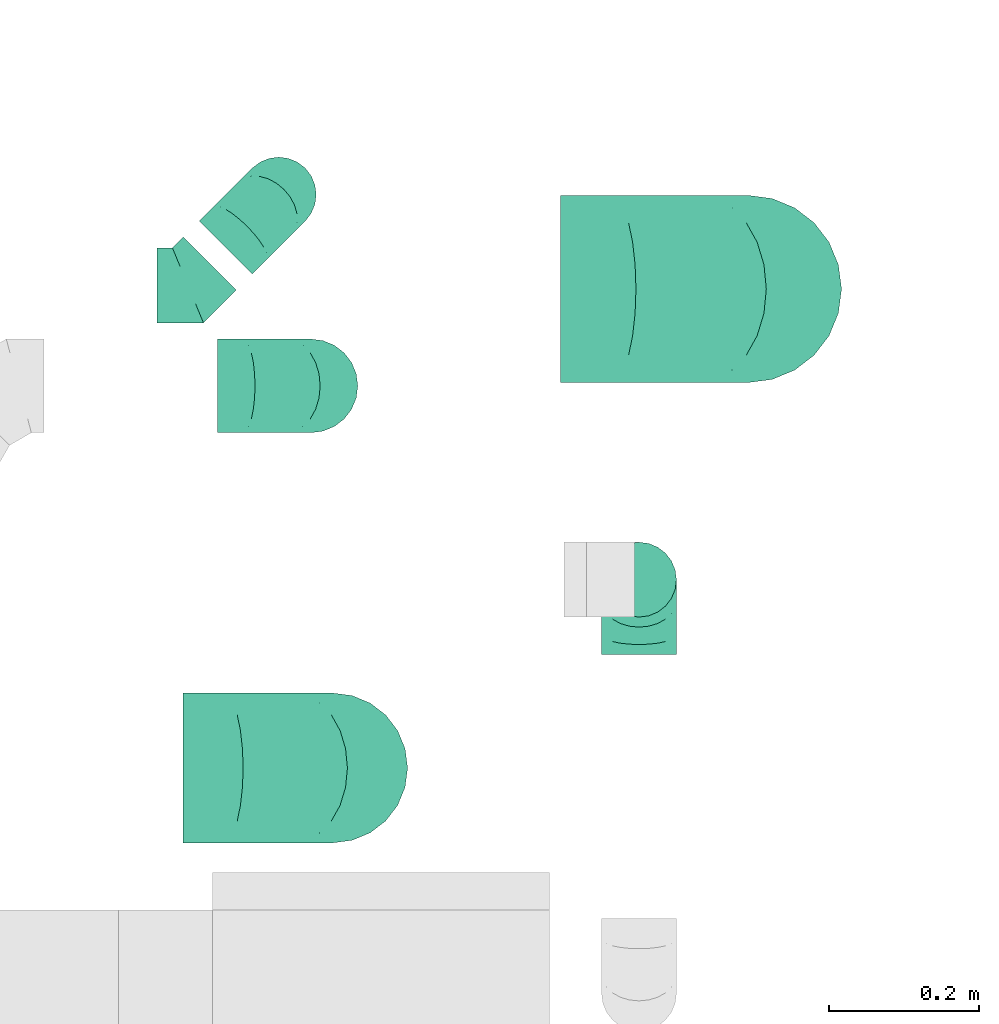
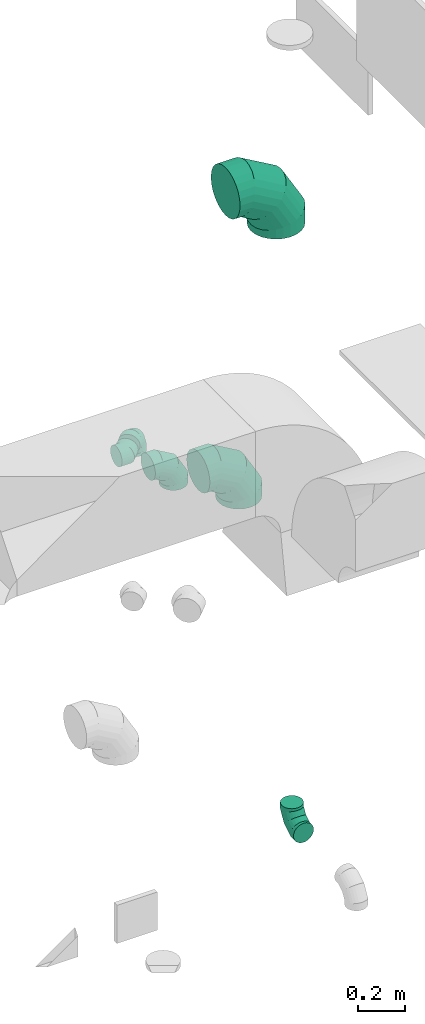
# One storey, part 39 of 59: 6 flow fittings.
"""IFC2X3 building model written with IfcOpenShell, lengths in millimetres."""

from ifc_helpers import new_model, entity, si_unit, converted_unit, derived_unit, direction, frame, origin, place, context, subcontext, project, spatial, faceted_brep, source, transform, mapped, material, type_object, type_shapes, element, save


model = new_model("IFC2X3")

# Units and contexts
model_context = context("Model", 3, precision=0.01, world=origin(), true_north=direction((6.12303176911189e-17, 1.0)))
body_context = subcontext(model_context, "Body", "Model", "MODEL_VIEW")
ifc_project = project(units=[si_unit("LENGTHUNIT", "METRE", prefix="MILLI"), si_unit("AREAUNIT", "SQUARE_METRE"), si_unit("VOLUMEUNIT", "CUBIC_METRE"), converted_unit("PLANEANGLEUNIT", "DEGREE", entity("IfcRatioMeasure", 0.0174532925199433), si_unit("PLANEANGLEUNIT", "RADIAN"), dimensions=[0, 0, 0, 0, 0, 0, 0]), si_unit("MASSUNIT", "GRAM", prefix="KILO"), derived_unit("MASSDENSITYUNIT", [(si_unit("MASSUNIT", "GRAM", prefix="KILO"), 1), (si_unit("LENGTHUNIT", "METRE"), -3)]), derived_unit("MOMENTOFINERTIAUNIT", [(si_unit("LENGTHUNIT", "METRE"), 4)]), si_unit("TIMEUNIT", "SECOND"), si_unit("FREQUENCYUNIT", "HERTZ"), si_unit("THERMODYNAMICTEMPERATUREUNIT", "DEGREE_CELSIUS"), derived_unit("THERMALTRANSMITTANCEUNIT", [(si_unit("MASSUNIT", "GRAM", prefix="KILO"), 1), (si_unit("THERMODYNAMICTEMPERATUREUNIT", "KELVIN"), -1), (si_unit("TIMEUNIT", "SECOND"), -3)]), derived_unit("VOLUMETRICFLOWRATEUNIT", [(si_unit("LENGTHUNIT", "METRE"), 3), (si_unit("TIMEUNIT", "SECOND"), -1)]), derived_unit("MASSFLOWRATEUNIT", [(si_unit("MASSUNIT", "GRAM", prefix="KILO"), 1), (si_unit("TIMEUNIT", "SECOND"), -1)]), derived_unit("ROTATIONALFREQUENCYUNIT", [(si_unit("TIMEUNIT", "SECOND"), -1)]), si_unit("ELECTRICCURRENTUNIT", "AMPERE"), si_unit("ELECTRICVOLTAGEUNIT", "VOLT"), si_unit("POWERUNIT", "WATT"), si_unit("FORCEUNIT", "NEWTON", prefix="KILO"), si_unit("ILLUMINANCEUNIT", "LUX"), si_unit("LUMINOUSFLUXUNIT", "LUMEN"), si_unit("LUMINOUSINTENSITYUNIT", "CANDELA"), derived_unit("USERDEFINED", [(si_unit("MASSUNIT", "GRAM", prefix="KILO"), -1), (si_unit("LENGTHUNIT", "METRE"), -2), (si_unit("TIMEUNIT", "SECOND"), 3), (si_unit("LUMINOUSFLUXUNIT", "LUMEN"), 1)]), derived_unit("LINEARVELOCITYUNIT", [(si_unit("LENGTHUNIT", "METRE"), 1), (si_unit("TIMEUNIT", "SECOND"), -1)]), si_unit("PRESSUREUNIT", "PASCAL"), derived_unit("USERDEFINED", [(si_unit("LENGTHUNIT", "METRE"), -2), (si_unit("MASSUNIT", "GRAM", prefix="KILO"), 1), (si_unit("TIMEUNIT", "SECOND"), -2)]), derived_unit("LINEARFORCEUNIT", [(si_unit("MASSUNIT", "GRAM", prefix="KILO"), 1), (si_unit("LENGTHUNIT", "METRE"), 1), (si_unit("TIMEUNIT", "SECOND"), -2), (si_unit("LENGTHUNIT", "METRE"), -1)]), derived_unit("PLANARFORCEUNIT", [(si_unit("MASSUNIT", "GRAM", prefix="KILO"), 1), (si_unit("LENGTHUNIT", "METRE"), 1), (si_unit("TIMEUNIT", "SECOND"), -2), (si_unit("LENGTHUNIT", "METRE"), -2)])], contexts=[model_context])

# Site, building, storey
site_placement = place(None, origin())
site = spatial("IfcSite", under=ifc_project, at=site_placement, CompositionType="ELEMENT")
building_placement = place(site_placement, origin())
building = spatial("IfcBuilding", under=site, at=building_placement, CompositionType="ELEMENT")
storey_placement = place(building_placement, frame((0.0, 0.0, 28200.0)))
storey = spatial("IfcBuildingStorey", under=building, at=storey_placement, CompositionType="ELEMENT", Elevation=28200.0)

# Flow fittings
ifc_material = material()
duct_fitting_type_1 = type_object("IfcDuctFittingType", PredefinedType="NOTDEFINED", material=ifc_material)
shared_shape_1 = source(origin(), body_context, "Body", "Brep", [
    faceted_brep([(-100.0, 0.0, -50.0), (-100.0, -12.94, -48.3), (-100.0, -25.0, -43.3), (-100.0, -35.36, -35.36), (-100.0, -43.3, -25.0), (-100.0, -48.3, -12.94), (-100.0, -50.0, 0.0), (-100.0, -48.3, 12.94), (-100.0, -43.3, 25.0), (-100.0, -35.36, 35.36), (-100.0, -25.0, 43.3), (-100.0, -12.94, 48.3), (-100.0, 0.0, 50.0), (-100.0, 12.94, 48.3), (-100.0, 25.0, 43.3), (-100.0, 35.36, 35.36), (-100.0, 43.3, 25.0), (-100.0, 48.3, 12.94), (-100.0, 50.0, 0.0), (-100.0, 48.3, -12.94), (-100.0, 43.3, -25.0), (-100.0, 35.36, -35.36), (-100.0, 25.0, -43.3), (-100.0, 12.94, -48.3), (-76.67, 12.94, 48.3), (-79.9, 25.0, 43.3), (-73.21, 0.0, 50.0), (-82.68, 35.36, 35.36), (-86.15, 48.3, 12.94), (-86.6, 50.0, 0.0), (-84.81, 43.3, 25.0), (-84.81, 43.3, -25.0), (-82.68, 35.36, -35.36), (-86.15, 48.3, -12.94), (-76.67, 12.94, -48.3), (-73.21, 0.0, -50.0), (-79.9, 25.0, -43.3), (-69.74, -12.94, -48.3), (-66.51, -25.0, -43.3), (-63.73, -35.36, -35.36), (-61.6, -43.3, -25.0), (-60.26, -48.3, -12.94), (-59.81, -50.0, 0.0), (-60.26, -48.3, 12.94), (-61.6, -43.3, 25.0), (-63.73, -35.36, 35.36), (-66.51, -25.0, 43.3), (-69.74, -12.94, 48.3), (-36.27, 36.27, 48.3), (-45.1, 45.1, 43.3), (-26.79, 26.79, 50.0), (-52.68, 52.68, 35.36), (-58.49, 58.49, 25.0), (-62.15, 62.15, 12.94), (-63.4, 63.4, 0.0), (-62.15, 62.15, -12.94), (-58.49, 58.49, -25.0), (-52.68, 52.68, -35.36), (-36.27, 36.27, -48.3), (-26.79, 26.79, -50.0), (-45.1, 45.1, -43.3), (-17.32, 17.32, -48.3), (-8.49, 8.49, -43.3), (-0.91, 0.91, -35.36), (4.9, -4.9, -25.0), (8.56, -8.56, -12.94), (9.81, -9.81, 0.0), (8.56, -8.56, 12.94), (4.9, -4.9, 25.0), (-0.91, 0.91, 35.36), (-8.49, 8.49, 43.3), (-17.32, 17.32, 48.3), (-12.94, 76.67, 48.3), (-25.0, 79.9, 43.3), (0.0, 73.21, 50.0), (-35.36, 82.68, 35.36), (-43.3, 84.81, 25.0), (-48.3, 86.15, 12.94), (-50.0, 86.6, 0.0), (-48.3, 86.15, -12.94), (-43.3, 84.81, -25.0), (-35.36, 82.68, -35.36), (-12.94, 76.67, -48.3), (0.0, 73.21, -50.0), (-25.0, 79.9, -43.3), (12.94, 69.74, -48.3), (25.0, 66.51, -43.3), (35.36, 63.73, -35.36), (43.3, 61.6, -25.0), (48.3, 60.26, -12.94), (50.0, 59.81, 0.0), (48.3, 60.26, 12.94), (43.3, 61.6, 25.0), (35.36, 63.73, 35.36), (25.0, 66.51, 43.3), (12.94, 69.74, 48.3), (-12.94, 100.0, -48.3), (-25.0, 100.0, -43.3), (-35.36, 100.0, -35.36), (-43.3, 100.0, -25.0), (-48.3, 100.0, -12.94), (-50.0, 100.0, 0.0), (-48.3, 100.0, 12.94), (-43.3, 100.0, 25.0), (-35.36, 100.0, 35.36), (-25.0, 100.0, 43.3), (-12.94, 100.0, 48.3), (0.0, 100.0, 50.0), (12.94, 100.0, 48.3), (25.0, 100.0, 43.3), (35.36, 100.0, 35.36), (43.3, 100.0, 25.0), (48.3, 100.0, 12.94), (50.0, 100.0, 0.0), (48.3, 100.0, -12.94), (43.3, 100.0, -25.0), (35.36, 100.0, -35.36), (25.0, 100.0, -43.3), (12.94, 100.0, -48.3), (0.0, 100.0, -50.0)], [[[0, 1, 2, 3, 4, 5, 6, 7, 8, 9, 10, 11, 12, 13, 14, 15, 16, 17, 18, 19, 20, 21, 22, 23]], [[24, 25, 14, 13]], [[26, 24, 13, 12]], [[14, 25, 27, 15]], [[28, 29, 18, 17]], [[30, 28, 17, 16]], [[15, 27, 30, 16]], [[20, 31, 32, 21]], [[33, 31, 20, 19]], [[18, 29, 33, 19]], [[34, 35, 0, 23]], [[36, 34, 23, 22]], [[32, 36, 22, 21]], [[2, 1, 37, 38]], [[3, 2, 38, 39]], [[0, 35, 37, 1]], [[5, 4, 40, 41]], [[6, 5, 41, 42]], [[3, 39, 40, 4]], [[6, 42, 43, 7]], [[7, 43, 44, 8]], [[8, 44, 45, 9]], [[10, 46, 47, 11]], [[11, 47, 26, 12]], [[10, 9, 45, 46]], [[48, 49, 25, 24]], [[50, 48, 24, 26]], [[27, 25, 49, 51]], [[52, 53, 28, 30]], [[51, 52, 30, 27]], [[29, 28, 53, 54]], [[55, 56, 31, 33]], [[54, 55, 33, 29]], [[57, 32, 31, 56]], [[58, 59, 35, 34]], [[60, 58, 34, 36]], [[57, 60, 36, 32]], [[37, 35, 59, 61]], [[38, 37, 61, 62]], [[39, 38, 62, 63]], [[41, 40, 64, 65]], [[42, 41, 65, 66]], [[63, 64, 40, 39]], [[43, 42, 66, 67]], [[44, 43, 67, 68]], [[68, 69, 45, 44]], [[46, 45, 69, 70]], [[47, 46, 70, 71]], [[26, 47, 71, 50]], [[72, 73, 49, 48]], [[74, 72, 48, 50]], [[51, 49, 73, 75]], [[76, 77, 53, 52]], [[75, 76, 52, 51]], [[54, 53, 77, 78]], [[79, 80, 56, 55]], [[78, 79, 55, 54]], [[81, 57, 56, 80]], [[82, 83, 59, 58]], [[84, 82, 58, 60]], [[81, 84, 60, 57]], [[61, 59, 83, 85]], [[62, 61, 85, 86]], [[63, 62, 86, 87]], [[65, 64, 88, 89]], [[66, 65, 89, 90]], [[87, 88, 64, 63]], [[67, 66, 90, 91]], [[68, 67, 91, 92]], [[92, 93, 69, 68]], [[70, 69, 93, 94]], [[71, 70, 94, 95]], [[50, 71, 95, 74]], [[96, 97, 98, 99, 100, 101, 102, 103, 104, 105, 106, 107, 108, 109, 110, 111, 112, 113, 114, 115, 116, 117, 118, 119]], [[72, 74, 107, 106]], [[73, 72, 106, 105]], [[75, 73, 105, 104]], [[77, 76, 103, 102]], [[78, 77, 102, 101]], [[75, 104, 103, 76]], [[78, 101, 100, 79]], [[79, 100, 99, 80]], [[80, 99, 98, 81]], [[96, 119, 83, 82]], [[97, 96, 82, 84]], [[84, 81, 98, 97]], [[83, 119, 118, 85]], [[85, 118, 117, 86]], [[86, 117, 116, 87]], [[88, 115, 114, 89]], [[89, 114, 113, 90]], [[87, 116, 115, 88]], [[91, 90, 113, 112]], [[92, 91, 112, 111]], [[93, 92, 111, 110]], [[95, 94, 109, 108]], [[74, 95, 108, 107]], [[110, 109, 94, 93]]]),
])
type_shapes(duct_fitting_type_1, [shared_shape_1])
for number, where, z_axis, x_axis in (
    (1, (59324.53, 12105.64, 400.0), (-1.0, 0.0, 0.0), (0.0, 0.0, -1.0)),
    (2, (58843.56, 12619.72, 2300.0), (-0.707106781186548, 0.707106781186548, 0.0), (0.707106781186548, 0.707106781186548, 0.0)),
):
    element("IfcFlowFitting", number, at=place(storey_placement, frame(where, z_axis=z_axis, x_axis=x_axis)), inside=storey, type_object=duct_fitting_type_1, material=ifc_material, context=body_context, shape_type="MappedRepresentation", body=[
        mapped(shared_shape_1, transform((0.0, 0.0, 0.0), scale=1.0)),
    ])
duct_fitting_type_2 = type_object("IfcDuctFittingType", PredefinedType="NOTDEFINED", material=ifc_material)
shared_shape_2 = source(origin(), body_context, "Body", "Brep", [
    faceted_brep([(-250.0, 0.0, -125.0), (-250.0, -32.35, -120.74), (-250.0, -62.5, -108.25), (-250.0, -88.39, -88.39), (-250.0, -108.25, -62.5), (-250.0, -120.74, -32.35), (-250.0, -125.0, 0.0), (-250.0, -120.74, 32.35), (-250.0, -108.25, 62.5), (-250.0, -88.39, 88.39), (-250.0, -62.5, 108.25), (-250.0, -32.35, 120.74), (-250.0, 0.0, 125.0), (-250.0, 32.35, 120.74), (-250.0, 62.5, 108.25), (-250.0, 88.39, 88.39), (-250.0, 108.25, 62.5), (-250.0, 120.74, 32.35), (-250.0, 125.0, 0.0), (-250.0, 120.74, -32.35), (-250.0, 108.25, -62.5), (-250.0, 88.39, -88.39), (-250.0, 62.5, -108.25), (-250.0, 32.35, -120.74), (-191.68, 32.35, 120.74), (-199.76, 62.5, 108.25), (-183.01, 0.0, 125.0), (-206.7, 88.39, 88.39), (-215.37, 120.74, 32.35), (-216.51, 125.0, 0.0), (-212.02, 108.25, 62.5), (-212.02, 108.25, -62.5), (-206.7, 88.39, -88.39), (-215.37, 120.74, -32.35), (-191.68, 32.35, -120.74), (-183.01, 0.0, -125.0), (-199.76, 62.5, -108.25), (-174.34, -32.35, -120.74), (-166.27, -62.5, -108.25), (-159.33, -88.39, -88.39), (-154.01, -108.25, -62.5), (-150.66, -120.74, -32.35), (-149.52, -125.0, 0.0), (-150.66, -120.74, 32.35), (-154.01, -108.25, 62.5), (-159.33, -88.39, 88.39), (-166.27, -62.5, 108.25), (-174.34, -32.35, 120.74), (-90.67, 90.67, 120.74), (-112.74, 112.74, 108.25), (-66.99, 66.99, 125.0), (-131.69, 131.69, 88.39), (-146.23, 146.23, 62.5), (-155.38, 155.38, 32.35), (-158.49, 158.49, 0.0), (-155.38, 155.38, -32.35), (-146.23, 146.23, -62.5), (-131.69, 131.69, -88.39), (-90.67, 90.67, -120.74), (-66.99, 66.99, -125.0), (-112.74, 112.74, -108.25), (-43.3, 43.3, -120.74), (-21.23, 21.23, -108.25), (-2.28, 2.28, -88.39), (12.26, -12.26, -62.5), (21.4, -21.4, -32.35), (24.52, -24.52, 0.0), (21.4, -21.4, 32.35), (12.26, -12.26, 62.5), (-2.28, 2.28, 88.39), (-21.23, 21.23, 108.25), (-43.3, 43.3, 120.74), (-32.35, 191.68, 120.74), (-62.5, 199.76, 108.25), (0.0, 183.01, 125.0), (-88.39, 206.7, 88.39), (-108.25, 212.02, 62.5), (-120.74, 215.37, 32.35), (-125.0, 216.51, 0.0), (-120.74, 215.37, -32.35), (-108.25, 212.02, -62.5), (-88.39, 206.7, -88.39), (-32.35, 191.68, -120.74), (0.0, 183.01, -125.0), (-62.5, 199.76, -108.25), (32.35, 174.34, -120.74), (62.5, 166.27, -108.25), (88.39, 159.33, -88.39), (108.25, 154.01, -62.5), (120.74, 150.66, -32.35), (125.0, 149.52, 0.0), (120.74, 150.66, 32.35), (108.25, 154.01, 62.5), (88.39, 159.33, 88.39), (62.5, 166.27, 108.25), (32.35, 174.34, 120.74), (-32.35, 250.0, -120.74), (-62.5, 250.0, -108.25), (-88.39, 250.0, -88.39), (-108.25, 250.0, -62.5), (-120.74, 250.0, -32.35), (-125.0, 250.0, 0.0), (-120.74, 250.0, 32.35), (-108.25, 250.0, 62.5), (-88.39, 250.0, 88.39), (-62.5, 250.0, 108.25), (-32.35, 250.0, 120.74), (0.0, 250.0, 125.0), (32.35, 250.0, 120.74), (62.5, 250.0, 108.25), (88.39, 250.0, 88.39), (108.25, 250.0, 62.5), (120.74, 250.0, 32.35), (125.0, 250.0, 0.0), (120.74, 250.0, -32.35), (108.25, 250.0, -62.5), (88.39, 250.0, -88.39), (62.5, 250.0, -108.25), (32.35, 250.0, -120.74), (0.0, 250.0, -125.0)], [[[0, 1, 2, 3, 4, 5, 6, 7, 8, 9, 10, 11, 12, 13, 14, 15, 16, 17, 18, 19, 20, 21, 22, 23]], [[24, 25, 14, 13]], [[26, 24, 13, 12]], [[14, 25, 27, 15]], [[28, 29, 18, 17]], [[30, 28, 17, 16]], [[15, 27, 30, 16]], [[20, 31, 32, 21]], [[33, 31, 20, 19]], [[18, 29, 33, 19]], [[34, 35, 0, 23]], [[36, 34, 23, 22]], [[21, 32, 36, 22]], [[1, 0, 35, 37]], [[2, 1, 37, 38]], [[38, 39, 3, 2]], [[5, 4, 40, 41]], [[6, 5, 41, 42]], [[39, 40, 4, 3]], [[6, 42, 43, 7]], [[7, 43, 44, 8]], [[8, 44, 45, 9]], [[9, 45, 46, 10]], [[10, 46, 47, 11]], [[26, 12, 11, 47]], [[48, 49, 25, 24]], [[50, 48, 24, 26]], [[27, 25, 49, 51]], [[52, 53, 28, 30]], [[51, 52, 30, 27]], [[29, 28, 53, 54]], [[55, 56, 31, 33]], [[54, 55, 33, 29]], [[32, 31, 56, 57]], [[58, 59, 35, 34]], [[60, 58, 34, 36]], [[57, 60, 36, 32]], [[37, 35, 59, 61]], [[38, 37, 61, 62]], [[39, 38, 62, 63]], [[41, 40, 64, 65]], [[42, 41, 65, 66]], [[63, 64, 40, 39]], [[43, 42, 66, 67]], [[44, 43, 67, 68]], [[68, 69, 45, 44]], [[46, 45, 69, 70]], [[47, 46, 70, 71]], [[26, 47, 71, 50]], [[72, 73, 49, 48]], [[74, 72, 48, 50]], [[51, 49, 73, 75]], [[76, 77, 53, 52]], [[75, 76, 52, 51]], [[54, 53, 77, 78]], [[79, 80, 56, 55]], [[78, 79, 55, 54]], [[57, 56, 80, 81]], [[82, 83, 59, 58]], [[84, 82, 58, 60]], [[81, 84, 60, 57]], [[61, 59, 83, 85]], [[62, 61, 85, 86]], [[63, 62, 86, 87]], [[65, 64, 88, 89]], [[66, 65, 89, 90]], [[87, 88, 64, 63]], [[67, 66, 90, 91]], [[68, 67, 91, 92]], [[92, 93, 69, 68]], [[70, 69, 93, 94]], [[71, 70, 94, 95]], [[50, 71, 95, 74]], [[96, 97, 98, 99, 100, 101, 102, 103, 104, 105, 106, 107, 108, 109, 110, 111, 112, 113, 114, 115, 116, 117, 118, 119]], [[72, 74, 107, 106]], [[73, 72, 106, 105]], [[75, 73, 105, 104]], [[77, 76, 103, 102]], [[78, 77, 102, 101]], [[75, 104, 103, 76]], [[78, 101, 100, 79]], [[79, 100, 99, 80]], [[80, 99, 98, 81]], [[84, 97, 96, 82]], [[82, 96, 119, 83]], [[84, 81, 98, 97]], [[83, 119, 118, 85]], [[85, 118, 117, 86]], [[116, 87, 86, 117]], [[88, 115, 114, 89]], [[89, 114, 113, 90]], [[115, 88, 87, 116]], [[91, 90, 113, 112]], [[92, 91, 112, 111]], [[111, 110, 93, 92]], [[95, 94, 109, 108]], [[74, 95, 108, 107]], [[110, 109, 94, 93]]]),
])
type_shapes(duct_fitting_type_2, [shared_shape_2])
flow_fitting_1_placement = place(storey_placement, frame((59469.99, 12493.72, 3500.0), z_axis=(0.0, 1.0, 0.0), x_axis=(1.0, 0.0, 0.0)))
element("IfcFlowFitting", 3, at=flow_fitting_1_placement, inside=storey, type_object=duct_fitting_type_2, material=ifc_material, context=body_context, shape_type="MappedRepresentation", body=[
    mapped(shared_shape_2, transform((0.0, 0.0, 0.0), scale=1.0)),
])
duct_fitting_type_3 = type_object("IfcDuctFittingType", PredefinedType="NOTDEFINED", material=ifc_material)
shared_shape_3 = source(origin(), body_context, "Body", "Brep", [
    faceted_brep([(-200.0, 0.0, -100.0), (-200.0, -25.88, -96.59), (-200.0, -50.0, -86.6), (-200.0, -70.71, -70.71), (-200.0, -86.6, -50.0), (-200.0, -96.59, -25.88), (-200.0, -100.0, 0.0), (-200.0, -96.59, 25.88), (-200.0, -86.6, 50.0), (-200.0, -70.71, 70.71), (-200.0, -50.0, 86.6), (-200.0, -25.88, 96.59), (-200.0, 0.0, 100.0), (-200.0, 25.88, 96.59), (-200.0, 50.0, 86.6), (-200.0, 70.71, 70.71), (-200.0, 86.6, 50.0), (-200.0, 96.59, 25.88), (-200.0, 100.0, 0.0), (-200.0, 96.59, -25.88), (-200.0, 86.6, -50.0), (-200.0, 70.71, -70.71), (-200.0, 50.0, -86.6), (-200.0, 25.88, -96.59), (-153.35, 25.88, 96.59), (-159.81, 50.0, 86.6), (-146.41, 0.0, 100.0), (-165.36, 70.71, 70.71), (-172.29, 96.59, 25.88), (-173.21, 100.0, 0.0), (-169.62, 86.6, 50.0), (-169.62, 86.6, -50.0), (-165.36, 70.71, -70.71), (-172.29, 96.59, -25.88), (-153.35, 25.88, -96.59), (-146.41, 0.0, -100.0), (-159.81, 50.0, -86.6), (-139.48, -25.88, -96.59), (-133.01, -50.0, -86.6), (-127.46, -70.71, -70.71), (-123.21, -86.6, -50.0), (-120.53, -96.59, -25.88), (-119.62, -100.0, 0.0), (-120.53, -96.59, 25.88), (-123.21, -86.6, 50.0), (-127.46, -70.71, 70.71), (-133.01, -50.0, 86.6), (-139.48, -25.88, 96.59), (-72.54, 72.54, 96.59), (-90.19, 90.19, 86.6), (-53.59, 53.59, 100.0), (-105.35, 105.35, 70.71), (-116.99, 116.99, 50.0), (-124.3, 124.3, 25.88), (-126.79, 126.79, 0.0), (-124.3, 124.3, -25.88), (-116.99, 116.99, -50.0), (-105.35, 105.35, -70.71), (-72.54, 72.54, -96.59), (-53.59, 53.59, -100.0), (-90.19, 90.19, -86.6), (-34.64, 34.64, -96.59), (-16.99, 16.99, -86.6), (-1.83, 1.83, -70.71), (9.81, -9.81, -50.0), (17.12, -17.12, -25.88), (19.62, -19.62, 0.0), (17.12, -17.12, 25.88), (9.81, -9.81, 50.0), (-1.83, 1.83, 70.71), (-16.99, 16.99, 86.6), (-34.64, 34.64, 96.59), (-25.88, 153.35, 96.59), (-50.0, 159.81, 86.6), (0.0, 146.41, 100.0), (-70.71, 165.36, 70.71), (-86.6, 169.62, 50.0), (-96.59, 172.29, 25.88), (-100.0, 173.21, 0.0), (-96.59, 172.29, -25.88), (-86.6, 169.62, -50.0), (-70.71, 165.36, -70.71), (-25.88, 153.35, -96.59), (0.0, 146.41, -100.0), (-50.0, 159.81, -86.6), (25.88, 139.48, -96.59), (50.0, 133.01, -86.6), (70.71, 127.46, -70.71), (86.6, 123.21, -50.0), (96.59, 120.53, -25.88), (100.0, 119.62, 0.0), (96.59, 120.53, 25.88), (86.6, 123.21, 50.0), (70.71, 127.46, 70.71), (50.0, 133.01, 86.6), (25.88, 139.48, 96.59), (-25.88, 200.0, -96.59), (-50.0, 200.0, -86.6), (-70.71, 200.0, -70.71), (-86.6, 200.0, -50.0), (-96.59, 200.0, -25.88), (-100.0, 200.0, 0.0), (-96.59, 200.0, 25.88), (-86.6, 200.0, 50.0), (-70.71, 200.0, 70.71), (-50.0, 200.0, 86.6), (-25.88, 200.0, 96.59), (0.0, 200.0, 100.0), (25.88, 200.0, 96.59), (50.0, 200.0, 86.6), (70.71, 200.0, 70.71), (86.6, 200.0, 50.0), (96.59, 200.0, 25.88), (100.0, 200.0, 0.0), (96.59, 200.0, -25.88), (86.6, 200.0, -50.0), (70.71, 200.0, -70.71), (50.0, 200.0, -86.6), (25.88, 200.0, -96.59), (0.0, 200.0, -100.0)], [[[0, 1, 2, 3, 4, 5, 6, 7, 8, 9, 10, 11, 12, 13, 14, 15, 16, 17, 18, 19, 20, 21, 22, 23]], [[24, 25, 14, 13]], [[26, 24, 13, 12]], [[14, 25, 27, 15]], [[28, 29, 18, 17]], [[30, 28, 17, 16]], [[15, 27, 30, 16]], [[20, 31, 32, 21]], [[33, 31, 20, 19]], [[18, 29, 33, 19]], [[34, 35, 0, 23]], [[36, 34, 23, 22]], [[32, 36, 22, 21]], [[1, 0, 35, 37]], [[2, 1, 37, 38]], [[38, 39, 3, 2]], [[5, 4, 40, 41]], [[6, 5, 41, 42]], [[39, 40, 4, 3]], [[6, 42, 43, 7]], [[7, 43, 44, 8]], [[8, 44, 45, 9]], [[9, 45, 46, 10]], [[10, 46, 47, 11]], [[26, 12, 11, 47]], [[48, 49, 25, 24]], [[50, 48, 24, 26]], [[27, 25, 49, 51]], [[52, 53, 28, 30]], [[51, 52, 30, 27]], [[29, 28, 53, 54]], [[55, 56, 31, 33]], [[54, 55, 33, 29]], [[32, 31, 56, 57]], [[58, 59, 35, 34]], [[60, 58, 34, 36]], [[57, 60, 36, 32]], [[37, 35, 59, 61]], [[38, 37, 61, 62]], [[39, 38, 62, 63]], [[41, 40, 64, 65]], [[42, 41, 65, 66]], [[63, 64, 40, 39]], [[43, 42, 66, 67]], [[44, 43, 67, 68]], [[68, 69, 45, 44]], [[46, 45, 69, 70]], [[47, 46, 70, 71]], [[26, 47, 71, 50]], [[72, 73, 49, 48]], [[74, 72, 48, 50]], [[51, 49, 73, 75]], [[76, 77, 53, 52]], [[75, 76, 52, 51]], [[54, 53, 77, 78]], [[79, 80, 56, 55]], [[78, 79, 55, 54]], [[57, 56, 80, 81]], [[82, 83, 59, 58]], [[84, 82, 58, 60]], [[81, 84, 60, 57]], [[61, 59, 83, 85]], [[62, 61, 85, 86]], [[63, 62, 86, 87]], [[65, 64, 88, 89]], [[66, 65, 89, 90]], [[87, 88, 64, 63]], [[67, 66, 90, 91]], [[68, 67, 91, 92]], [[92, 93, 69, 68]], [[70, 69, 93, 94]], [[71, 70, 94, 95]], [[50, 71, 95, 74]], [[96, 97, 98, 99, 100, 101, 102, 103, 104, 105, 106, 107, 108, 109, 110, 111, 112, 113, 114, 115, 116, 117, 118, 119]], [[72, 74, 107, 106]], [[73, 72, 106, 105]], [[75, 73, 105, 104]], [[102, 101, 78, 77]], [[103, 102, 77, 76]], [[75, 104, 103, 76]], [[78, 101, 100, 79]], [[79, 100, 99, 80]], [[80, 99, 98, 81]], [[84, 97, 96, 82]], [[82, 96, 119, 83]], [[84, 81, 98, 97]], [[118, 117, 86, 85]], [[119, 118, 85, 83]], [[116, 87, 86, 117]], [[88, 115, 114, 89]], [[89, 114, 113, 90]], [[115, 88, 87, 116]], [[91, 90, 113, 112]], [[92, 91, 112, 111]], [[111, 110, 93, 92]], [[95, 94, 109, 108]], [[74, 95, 108, 107]], [[110, 109, 94, 93]]]),
])
type_shapes(duct_fitting_type_3, [shared_shape_3])
flow_fitting_2_placement = place(storey_placement, frame((58915.63, 11854.23, 2600.0), z_axis=(0.0, 1.0, 0.0), x_axis=(1.0, 0.0, 0.0)))
element("IfcFlowFitting", 4, at=flow_fitting_2_placement, inside=storey, type_object=duct_fitting_type_3, material=ifc_material, context=body_context, shape_type="MappedRepresentation", body=[
    mapped(shared_shape_3, transform((0.0, 0.0, 0.0), scale=1.0)),
])
duct_fitting_type_4 = type_object("IfcDuctFittingType", PredefinedType="NOTDEFINED", material=ifc_material)
shared_shape_4 = source(origin(), body_context, "Body", "Brep", [
    faceted_brep([(-125.0, 0.0, -62.5), (-125.0, -16.18, -60.37), (-125.0, -31.25, -54.13), (-125.0, -44.19, -44.19), (-125.0, -54.13, -31.25), (-125.0, -60.37, -16.18), (-125.0, -62.5, 0.0), (-125.0, -60.37, 16.18), (-125.0, -54.13, 31.25), (-125.0, -44.19, 44.19), (-125.0, -31.25, 54.13), (-125.0, -16.18, 60.37), (-125.0, 0.0, 62.5), (-125.0, 16.18, 60.37), (-125.0, 31.25, 54.13), (-125.0, 44.19, 44.19), (-125.0, 54.13, 31.25), (-125.0, 60.37, 16.18), (-125.0, 62.5, 0.0), (-125.0, 60.37, -16.18), (-125.0, 54.13, -31.25), (-125.0, 44.19, -44.19), (-125.0, 31.25, -54.13), (-125.0, 16.18, -60.37), (-95.84, 16.18, 60.37), (-99.88, 31.25, 54.13), (-91.51, 0.0, 62.5), (-103.35, 44.19, 44.19), (-107.68, 60.37, 16.18), (-108.25, 62.5, 0.0), (-106.01, 54.13, 31.25), (-106.01, 54.13, -31.25), (-103.35, 44.19, -44.19), (-107.68, 60.37, -16.18), (-95.84, 16.18, -60.37), (-91.51, 0.0, -62.5), (-99.88, 31.25, -54.13), (-87.17, -16.18, -60.37), (-83.13, -31.25, -54.13), (-79.66, -44.19, -44.19), (-77.0, -54.13, -31.25), (-75.33, -60.37, -16.18), (-74.76, -62.5, 0.0), (-75.33, -60.37, 16.18), (-77.0, -54.13, 31.25), (-79.66, -44.19, 44.19), (-83.13, -31.25, 54.13), (-87.17, -16.18, 60.37), (-45.34, 45.34, 60.37), (-56.37, 56.37, 54.13), (-33.49, 33.49, 62.5), (-65.85, 65.85, 44.19), (-73.12, 73.12, 31.25), (-77.69, 77.69, 16.18), (-79.25, 79.25, 0.0), (-77.69, 77.69, -16.18), (-73.12, 73.12, -31.25), (-65.85, 65.85, -44.19), (-45.34, 45.34, -60.37), (-33.49, 33.49, -62.5), (-56.37, 56.37, -54.13), (-21.65, 21.65, -60.37), (-10.62, 10.62, -54.13), (-1.14, 1.14, -44.19), (6.13, -6.13, -31.25), (10.7, -10.7, -16.18), (12.26, -12.26, 0.0), (10.7, -10.7, 16.18), (6.13, -6.13, 31.25), (-1.14, 1.14, 44.19), (-10.62, 10.62, 54.13), (-21.65, 21.65, 60.37), (-16.18, 95.84, 60.37), (-31.25, 99.88, 54.13), (0.0, 91.51, 62.5), (-44.19, 103.35, 44.19), (-54.13, 106.01, 31.25), (-60.37, 107.68, 16.18), (-62.5, 108.25, 0.0), (-60.37, 107.68, -16.18), (-54.13, 106.01, -31.25), (-44.19, 103.35, -44.19), (-16.18, 95.84, -60.37), (0.0, 91.51, -62.5), (-31.25, 99.88, -54.13), (16.18, 87.17, -60.37), (31.25, 83.13, -54.13), (44.19, 79.66, -44.19), (54.13, 77.0, -31.25), (60.37, 75.33, -16.18), (62.5, 74.76, 0.0), (60.37, 75.33, 16.18), (54.13, 77.0, 31.25), (44.19, 79.66, 44.19), (31.25, 83.13, 54.13), (16.18, 87.17, 60.37), (-16.18, 125.0, -60.37), (-31.25, 125.0, -54.13), (-44.19, 125.0, -44.19), (-54.13, 125.0, -31.25), (-60.37, 125.0, -16.18), (-62.5, 125.0, 0.0), (-60.37, 125.0, 16.18), (-54.13, 125.0, 31.25), (-44.19, 125.0, 44.19), (-31.25, 125.0, 54.13), (-16.18, 125.0, 60.37), (0.0, 125.0, 62.5), (16.18, 125.0, 60.37), (31.25, 125.0, 54.13), (44.19, 125.0, 44.19), (54.13, 125.0, 31.25), (60.37, 125.0, 16.18), (62.5, 125.0, 0.0), (60.37, 125.0, -16.18), (54.13, 125.0, -31.25), (44.19, 125.0, -44.19), (31.25, 125.0, -54.13), (16.18, 125.0, -60.37), (0.0, 125.0, -62.5)], [[[0, 1, 2, 3, 4, 5, 6, 7, 8, 9, 10, 11, 12, 13, 14, 15, 16, 17, 18, 19, 20, 21, 22, 23]], [[24, 25, 14, 13]], [[26, 24, 13, 12]], [[14, 25, 27, 15]], [[28, 29, 18, 17]], [[30, 28, 17, 16]], [[15, 27, 30, 16]], [[20, 31, 32, 21]], [[33, 31, 20, 19]], [[18, 29, 33, 19]], [[34, 35, 0, 23]], [[36, 34, 23, 22]], [[21, 32, 36, 22]], [[1, 0, 35, 37]], [[2, 1, 37, 38]], [[38, 39, 3, 2]], [[5, 4, 40, 41]], [[6, 5, 41, 42]], [[39, 40, 4, 3]], [[6, 42, 43, 7]], [[7, 43, 44, 8]], [[45, 9, 8, 44]], [[9, 45, 46, 10]], [[10, 46, 47, 11]], [[26, 12, 11, 47]], [[48, 49, 25, 24]], [[50, 48, 24, 26]], [[27, 25, 49, 51]], [[52, 53, 28, 30]], [[51, 52, 30, 27]], [[29, 28, 53, 54]], [[55, 56, 31, 33]], [[54, 55, 33, 29]], [[57, 32, 31, 56]], [[58, 59, 35, 34]], [[60, 58, 34, 36]], [[57, 60, 36, 32]], [[37, 35, 59, 61]], [[38, 37, 61, 62]], [[39, 38, 62, 63]], [[41, 40, 64, 65]], [[42, 41, 65, 66]], [[63, 64, 40, 39]], [[43, 42, 66, 67]], [[44, 43, 67, 68]], [[68, 69, 45, 44]], [[46, 45, 69, 70]], [[47, 46, 70, 71]], [[26, 47, 71, 50]], [[72, 73, 49, 48]], [[74, 72, 48, 50]], [[51, 49, 73, 75]], [[76, 77, 53, 52]], [[75, 76, 52, 51]], [[54, 53, 77, 78]], [[79, 80, 56, 55]], [[78, 79, 55, 54]], [[81, 57, 56, 80]], [[82, 83, 59, 58]], [[84, 82, 58, 60]], [[81, 84, 60, 57]], [[61, 59, 83, 85]], [[62, 61, 85, 86]], [[63, 62, 86, 87]], [[65, 64, 88, 89]], [[66, 65, 89, 90]], [[87, 88, 64, 63]], [[67, 66, 90, 91]], [[68, 67, 91, 92]], [[92, 93, 69, 68]], [[70, 69, 93, 94]], [[71, 70, 94, 95]], [[50, 71, 95, 74]], [[96, 97, 98, 99, 100, 101, 102, 103, 104, 105, 106, 107, 108, 109, 110, 111, 112, 113, 114, 115, 116, 117, 118, 119]], [[72, 74, 107, 106]], [[73, 72, 106, 105]], [[75, 73, 105, 104]], [[77, 76, 103, 102]], [[78, 77, 102, 101]], [[75, 104, 103, 76]], [[78, 101, 100, 79]], [[79, 100, 99, 80]], [[80, 99, 98, 81]], [[96, 119, 83, 82]], [[97, 96, 82, 84]], [[84, 81, 98, 97]], [[83, 119, 118, 85]], [[85, 118, 117, 86]], [[116, 87, 86, 117]], [[88, 115, 114, 89]], [[89, 114, 113, 90]], [[115, 88, 87, 116]], [[91, 90, 113, 112]], [[92, 91, 112, 111]], [[111, 110, 93, 92]], [[95, 94, 109, 108]], [[74, 95, 108, 107]], [[110, 109, 94, 93]]]),
])
type_shapes(duct_fitting_type_4, [shared_shape_4])
flow_fitting_3_placement = place(storey_placement, frame((58886.63, 12364.32, 2297.5), z_axis=(0.0, 1.0, 0.0), x_axis=(1.0, 0.0, 0.0)))
element("IfcFlowFitting", 5, at=flow_fitting_3_placement, inside=storey, type_object=duct_fitting_type_4, material=ifc_material, context=body_context, shape_type="MappedRepresentation", body=[
    mapped(shared_shape_4, transform((0.0, 0.0, 0.0), scale=1.0)),
])
duct_fitting_type_5 = type_object("IfcDuctFittingType", PredefinedType="NOTDEFINED", material=ifc_material)
shared_shape_5 = source(origin(), body_context, "Body", "Brep", [
    faceted_brep([(-41.42, 0.0, -50.0), (-41.42, -12.94, -48.3), (-41.42, -25.0, -43.3), (-41.42, -35.36, -35.36), (-41.42, -43.3, -25.0), (-41.42, -48.3, -12.94), (-41.42, -50.0, 0.0), (-41.42, -48.3, 12.94), (-41.42, -43.3, 25.0), (-41.42, -35.36, 35.36), (-41.42, -25.0, 43.3), (-41.42, -12.94, 48.3), (-41.42, 0.0, 50.0), (-41.42, 12.94, 48.3), (-41.42, 25.0, 43.3), (-41.42, 35.36, 35.36), (-41.42, 43.3, 25.0), (-41.42, 48.3, 12.94), (-41.42, 50.0, 0.0), (-41.42, 48.3, -12.94), (-41.42, 43.3, -25.0), (-41.42, 35.36, -35.36), (-41.42, 25.0, -43.3), (-41.42, 12.94, -48.3), (-5.36, 12.94, 48.3), (-10.36, 25.0, 43.3), (0.0, 0.0, 50.0), (-14.64, 35.36, 35.36), (-20.0, 48.3, 12.94), (-20.71, 50.0, 0.0), (-17.94, 43.3, 25.0), (-17.94, 43.3, -25.0), (-14.64, 35.36, -35.36), (-20.0, 48.3, -12.94), (-5.36, 12.94, -48.3), (0.0, 0.0, -50.0), (-10.36, 25.0, -43.3), (5.36, -12.94, -48.3), (10.36, -25.0, -43.3), (14.64, -35.36, -35.36), (17.94, -43.3, -25.0), (20.0, -48.3, -12.94), (20.71, -50.0, 0.0), (20.0, -48.3, 12.94), (17.94, -43.3, 25.0), (14.64, -35.36, 35.36), (10.36, -25.0, 43.3), (5.36, -12.94, 48.3), (29.29, 29.29, 50.0), (20.14, 38.44, 48.3), (11.61, 46.97, 43.3), (4.29, 54.29, 35.36), (-1.33, 59.91, 25.0), (-4.86, 63.44, 12.94), (-6.07, 64.64, 0.0), (-4.86, 63.44, -12.94), (-1.33, 59.91, -25.0), (4.29, 54.29, -35.36), (11.61, 46.97, -43.3), (20.14, 38.44, -48.3), (29.29, 29.29, -50.0), (38.44, 20.14, -48.3), (46.97, 11.61, -43.3), (54.29, 4.29, -35.36), (59.91, -1.33, -25.0), (63.44, -4.86, -12.94), (64.64, -6.07, 0.0), (63.44, -4.86, 12.94), (59.91, -1.33, 25.0), (54.29, 4.29, 35.36), (46.97, 11.61, 43.3), (38.44, 20.14, 48.3)], [[[0, 1, 2, 3, 4, 5, 6, 7, 8, 9, 10, 11, 12, 13, 14, 15, 16, 17, 18, 19, 20, 21, 22, 23]], [[24, 25, 14, 13]], [[26, 24, 13, 12]], [[14, 25, 27, 15]], [[28, 29, 18, 17]], [[30, 28, 17, 16]], [[16, 15, 27, 30]], [[20, 31, 32, 21]], [[33, 31, 20, 19]], [[18, 29, 33, 19]], [[34, 35, 0, 23]], [[36, 34, 23, 22]], [[32, 36, 22, 21]], [[1, 0, 35, 37]], [[2, 1, 37, 38]], [[38, 39, 3, 2]], [[5, 4, 40, 41]], [[6, 5, 41, 42]], [[39, 40, 4, 3]], [[6, 42, 43, 7]], [[7, 43, 44, 8]], [[8, 44, 45, 9]], [[9, 45, 46, 10]], [[10, 46, 47, 11]], [[26, 12, 11, 47]], [[24, 26, 48, 49]], [[25, 24, 49, 50]], [[27, 25, 50, 51]], [[28, 30, 52, 53]], [[29, 28, 53, 54]], [[27, 51, 52, 30]], [[29, 54, 55, 33]], [[33, 55, 56, 31]], [[31, 56, 57, 32]], [[36, 58, 59, 34]], [[34, 59, 60, 35]], [[36, 32, 57, 58]], [[61, 62, 38, 37]], [[60, 61, 37, 35]], [[63, 39, 38, 62]], [[40, 64, 65, 41]], [[41, 65, 66, 42]], [[64, 40, 39, 63]], [[43, 42, 66, 67]], [[44, 43, 67, 68]], [[68, 69, 45, 44]], [[47, 46, 70, 71]], [[26, 47, 71, 48]], [[69, 70, 46, 45]], [[59, 58, 57, 56, 55, 54, 53, 52, 51, 50, 49, 48, 71, 70, 69, 68, 67, 66, 65, 64, 63, 62, 61, 60]]]),
])
type_shapes(duct_fitting_type_5, [shared_shape_5])
flow_fitting_4_placement = place(storey_placement, frame((58722.34, 12498.5, 2300.0)))
element("IfcFlowFitting", 6, at=flow_fitting_4_placement, inside=storey, type_object=duct_fitting_type_5, material=ifc_material, context=body_context, shape_type="MappedRepresentation", body=[
    mapped(shared_shape_5, transform((0.0, 0.0, 0.0), scale=1.0)),
])

save(model, "model.ifc")
